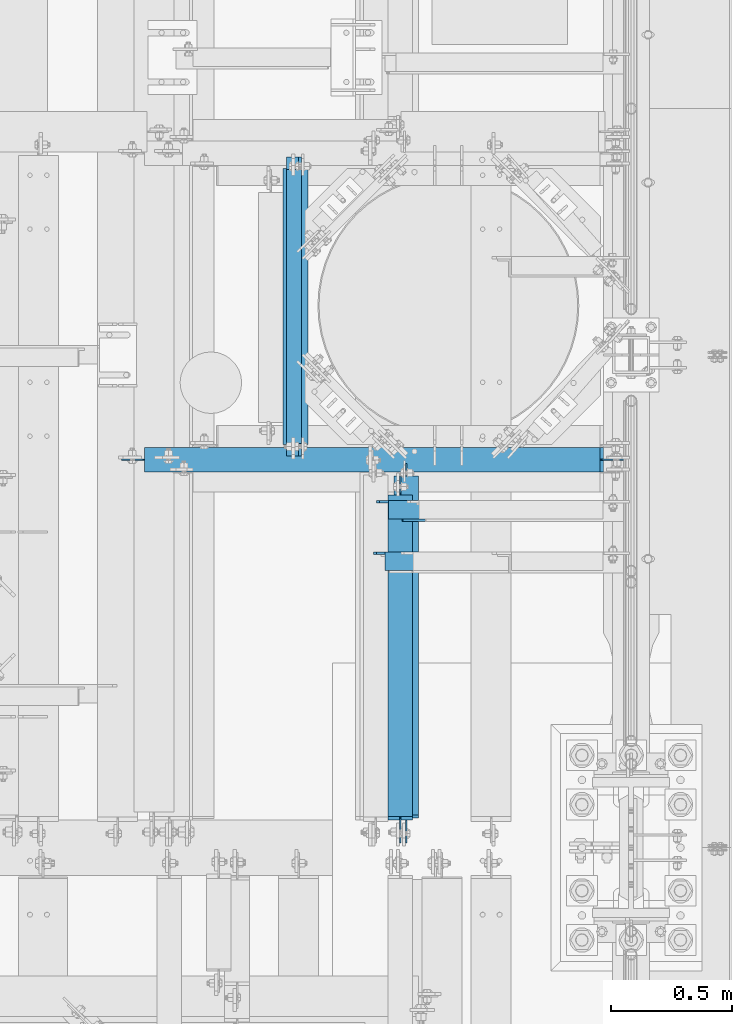
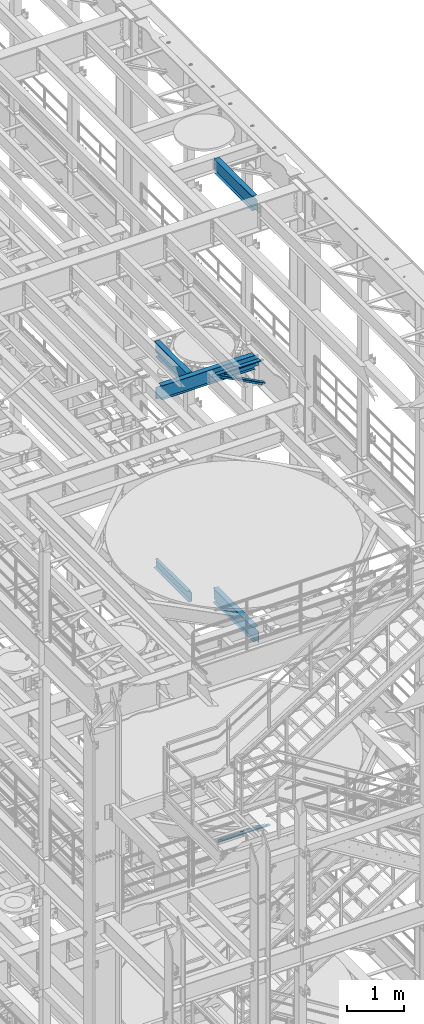
# One storey, part 1028 of 1876: 7 beams, 1 member, 8 elements without a shape of their own.
"""IFC2X3 building model written with IfcOpenShell, lengths in millimetres."""

import ifcopenshell
import ifcopenshell.guid

model = None  # the IFC model being written
_history = None  # IfcOwnerHistory: only IFC2X3 demands one
_inside = {}  # id of a spatial element -> (the spatial element, [elements in it])
_under = {}  # id of a project, library or spatial element -> (it, [spatial elements below it])
_declared = {}  # id of a project -> (the project, [libraries it declares])
_typed = {}  # id of a type object -> (the type object, [elements of that type])
_made_of = {}  # id of a material, layer set ... -> (it, [elements and type objects made of it])


def new_model(schema):
    """Start an empty IFC model of exactly this schema.

    Asked for "IFC4X3", IfcOpenShell would pick the latest addendum, in which some entities
    have other attributes; the version numbers below select the first issue.
    IFC2X3 requires an IfcOwnerHistory on every rooted entity: one is made here for all.
    """
    global model, _history
    if schema == "IFC4X3":
        model = ifcopenshell.file(schema_version=(4, 3, 0, 0))
    else:
        model = ifcopenshell.file(schema=schema)
    _inside.clear()
    _under.clear()
    _declared.clear()
    _typed.clear()
    _made_of.clear()
    _history = None
    if model.schema == "IFC2X3":
        org = make("IfcOrganization", Name="unknown")
        user = make(
            "IfcPersonAndOrganization",
            ThePerson=make("IfcPerson", FamilyName="unknown"),
            TheOrganization=org,
        )
        app = make(
            "IfcApplication",
            ApplicationDeveloper=org,
            Version="unknown",
            ApplicationFullName="unknown",
            ApplicationIdentifier="unknown",
        )
        _history = make(
            "IfcOwnerHistory",
            OwningUser=user,
            OwningApplication=app,
            ChangeAction="ADDED",
            CreationDate=0,
        )
    return model


def make(cls, **values):
    """One entity of the class cls with the attributes given. An attribute that is None is left unset."""
    return model.create_entity(
        cls, **{name: value for name, value in values.items() if value is not None}
    )


def rooted(cls, **values):
    """An entity with a GlobalId (a new one), such as an element, a storey or a relation."""
    return make(cls, GlobalId=ifcopenshell.guid.new(), OwnerHistory=_history, **values)


def si_unit(unit_type, name, prefix=None):
    """IfcSIUnit, for example si_unit("LENGTHUNIT", "METRE", prefix="MILLI")."""
    return make("IfcSIUnit", UnitType=unit_type, Prefix=prefix, Name=name)


def assignment(units):
    """IfcUnitAssignment: the units of a project."""
    return None if units is None else make("IfcUnitAssignment", Units=units)


def point(xyz):
    """IfcCartesianPoint."""
    return None if xyz is None else make("IfcCartesianPoint", Coordinates=xyz)


def direction(xyz):
    """IfcDirection."""
    return None if xyz is None else make("IfcDirection", DirectionRatios=xyz)


def frame(location, z_axis=None, x_axis=None):
    """IfcAxis2Placement3D, a coordinate frame: its origin and axes. An axis left out is left unset."""
    return make(
        "IfcAxis2Placement3D",
        Location=point(location),
        Axis=direction(z_axis),
        RefDirection=direction(x_axis),
    )


def origin_with_axes():
    """The frame at (0, 0, 0) with the z axis (0, 0, 1) and the x axis (1, 0, 0) written out."""
    return frame((0.0, 0.0, 0.0), z_axis=(0.0, 0.0, 1.0), x_axis=(1.0, 0.0, 0.0))


def place(relative_to, where):
    """IfcLocalPlacement: puts the frame where relative to a parent placement (None: the world)."""
    return make(
        "IfcLocalPlacement", PlacementRelTo=relative_to, RelativePlacement=where
    )


def context(
    kind, dimensions, precision=None, world=None, true_north=None, identifier=None
):
    """IfcGeometricRepresentationContext, for example the 3D "Model" context."""
    return make(
        "IfcGeometricRepresentationContext",
        ContextIdentifier=identifier,
        ContextType=kind,
        CoordinateSpaceDimension=dimensions,
        Precision=precision,
        WorldCoordinateSystem=world,
        TrueNorth=true_north,
    )


def subcontext(parent, identifier, kind, view, scale=None):
    """IfcGeometricRepresentationSubContext, for example "Body" below "Model"."""
    return make(
        "IfcGeometricRepresentationSubContext",
        ContextIdentifier=identifier,
        ContextType=kind,
        ParentContext=parent,
        TargetScale=scale,
        TargetView=view,
    )


def project(units=None, contexts=None):
    """IfcProject with its units and contexts."""
    return rooted(
        "IfcProject",
        Name="project",
        RepresentationContexts=contexts,
        UnitsInContext=assignment(units),
    )


def spatial(cls, under=None, at=None, **own):
    """A site, building, storey or space (cls), placed at a placement, below another one or the project."""
    s = rooted(cls, ObjectPlacement=at, **own)
    if under is not None:
        _under.setdefault(under.id(), (under, []))[1].append(s)
    return s


def faces_of(points, faces, orient=None, outer=None):
    """IfcFace entities. A face is a list of loops; a loop is a list of indices into points, from 0.

    orient and outer hold one flag for each loop. By default every Orientation is true, the
    first loop of a face is its IfcFaceOuterBound and the others are IfcFaceBound.
    """
    made = []
    for i, loops in enumerate(faces):
        bounds = []
        for j, loop in enumerate(loops):
            is_outer = j == 0 if outer is None else outer[i][j]
            bounds.append(
                make(
                    "IfcFaceOuterBound" if is_outer else "IfcFaceBound",
                    Bound=make("IfcPolyLoop", Polygon=[points[k] for k in loop]),
                    Orientation=True if orient is None else orient[i][j],
                )
            )
        made.append(make("IfcFace", Bounds=bounds))
    return made


def faceted_brep(points, faces, orient=None, outer=None, voids=None):
    """IfcFacetedBrep: a solid bounded by flat faces; with voids (closed shells), ...WithVoids."""
    shared = [point(p) for p in points]
    hull = make("IfcClosedShell", CfsFaces=faces_of(shared, faces, orient, outer))
    if voids is None:
        return make("IfcFacetedBrep", Outer=hull)
    return make(
        "IfcFacetedBrepWithVoids",
        Outer=hull,
        Voids=[
            make(cls, CfsFaces=faces_of(shared, fs, o, b)) for cls, fs, o, b in voids
        ],
    )


def shape(context_of_items, identifier, shape_type, items):
    """IfcShapeRepresentation: the items that make up one representation, for example the "Body"."""
    return make(
        "IfcShapeRepresentation",
        ContextOfItems=context_of_items,
        RepresentationIdentifier=identifier,
        RepresentationType=shape_type,
        Items=items,
    )


def material(Name=None, Category=None):
    """IfcMaterial."""
    return make("IfcMaterial", Name=Name, Category=Category)


def made_of(thing, what):
    """Note that an element or type object is made of a material, layer set ...; save() writes the relation."""
    if what is not None:
        _made_of.setdefault(what.id(), (what, []))[1].append(thing)
    return thing


def type_object(cls, material=None, **own):
    """A type object (cls), such as IfcWallType, which elements share."""
    return made_of(rooted(cls, **own), material)


def element(
    cls,
    number,
    at=None,
    inside=None,
    cuts=None,
    type_object=None,
    material=None,
    context=None,
    identifier="Body",
    shape_type=None,
    held_by="IfcProductDefinitionShape",
    body=None,
    shapes=None,
    **own,
):
    """One element of the class cls, such as IfcWall. Its Tag is "e" and its number.

    at: its placement. inside: the storey or other place that contains it. cuts: it is an
    opening in that element (IfcRelVoidsElement). A single representation is given by context,
    identifier, shape_type and body (its items); several are given by shapes. held_by: the class
    of the entity that holds the representations. save() writes the other relations.
    """
    e = rooted(cls, Tag="e%d" % number, ObjectPlacement=at, **own)
    if body is not None:
        shapes = [shape(context, identifier, shape_type, body)]
    if shapes is not None:
        e.Representation = make(held_by, Representations=shapes)
    if inside is not None:
        _inside.setdefault(inside.id(), (inside, []))[1].append(e)
    if cuts is not None:
        rooted(
            "IfcRelVoidsElement", RelatingBuildingElement=cuts, RelatedOpeningElement=e
        )
    if type_object is not None:
        _typed.setdefault(type_object.id(), (type_object, []))[1].append(e)
    return made_of(e, material)


def aggregate(whole, parts):
    """IfcRelAggregates: a whole, such as a stair, and the parts it consists of."""
    return rooted("IfcRelAggregates", RelatingObject=whole, RelatedObjects=parts)


def save(model, path):
    """Write the relations noted so far, then the file.

    IfcRelAggregates (storeys below a building ...), IfcRelContainedInSpatialStructure (elements
    in a storey), IfcRelDefinesByType, IfcRelAssociatesMaterial and IfcRelDeclares: one each for
    every whole, place, type object, material and project.
    """
    for whole, parts in _under.values():
        aggregate(whole, parts)
    for where, things in _inside.values():
        rooted(
            "IfcRelContainedInSpatialStructure",
            RelatedElements=things,
            RelatingStructure=where,
        )
    for kind, things in _typed.values():
        rooted("IfcRelDefinesByType", RelatedObjects=things, RelatingType=kind)
    for what, things in _made_of.values():
        rooted("IfcRelAssociatesMaterial", RelatedObjects=things, RelatingMaterial=what)
    for by, libraries in _declared.values():
        rooted("IfcRelDeclares", RelatingContext=by, RelatedDefinitions=libraries)
    model.write(path)


model = new_model("IFC2X3")

# Units and contexts
model_context = context("Model", 3, precision=1e-05, world=origin_with_axes())
body_context = subcontext(model_context, "Body", "Model", "MODEL_VIEW")
ifc_project = project(units=[si_unit("LENGTHUNIT", "METRE", prefix="MILLI"), si_unit("AREAUNIT", "SQUARE_METRE"), si_unit("VOLUMEUNIT", "CUBIC_METRE"), si_unit("MASSUNIT", "GRAM", prefix="KILO"), si_unit("TIMEUNIT", "SECOND"), si_unit("PLANEANGLEUNIT", "RADIAN"), si_unit("SOLIDANGLEUNIT", "STERADIAN"), si_unit("THERMODYNAMICTEMPERATUREUNIT", "DEGREE_CELSIUS"), si_unit("LUMINOUSINTENSITYUNIT", "LUMEN")], contexts=[model_context])

# Site, building, storey
site_placement = place(None, origin_with_axes())
site = spatial("IfcSite", under=ifc_project, at=site_placement, CompositionType="ELEMENT")
building_placement = place(site_placement, origin_with_axes())
building = spatial("IfcBuilding", under=site, at=building_placement, Name="Undefined", CompositionType="ELEMENT")
storey_placement = place(building_placement, origin_with_axes())
storey = spatial("IfcBuildingStorey", under=building, at=storey_placement, Name="Undefined", CompositionType="ELEMENT", Elevation=0.0)

# Assembly, member
assembly_1_placement = place(storey_placement, origin_with_axes())
assembly_1 = element("IfcElementAssembly", 1, at=assembly_1_placement, inside=storey, AssemblyPlace="NOTDEFINED", PredefinedType="RIGID_FRAME")
ifc_material_1 = material(Name="STEEL/A36")
member_type = type_object("IfcMemberType", Name="L3X3X3/8", PredefinedType="NOTDEFINED")
member_placement = place(assembly_1_placement, frame((6548.05484608427, 2908.3, 17987.6375508032), z_axis=(0.0, -1.0, 0.0), x_axis=(0.883528850284789, 0.0, -0.46837674015096)))
member = element("IfcMember", 2, at=member_placement, type_object=member_type, material=ifc_material_1, ObjectType="L3X3X3/8", context=body_context, shape_type="Brep", body=[
    faceted_brep([(128.795891913077, 38.1000000000095, -38.0999999999999), (128.795891913077, 38.1000000000095, 38.0999999999999), (1170.59703232476, 38.0999999999913, 38.0999999999999), (1170.59703232476, 38.0999999999913, -38.0999999999999), (128.795891913076, 28.575000000008, 38.0999999999999), (1170.59703232476, 28.5749999999898, 38.0999999999999), (128.795891913076, 28.575000000008, -28.5749999999998), (1170.59703232476, 28.5749999999898, -28.5749999999998), (128.79589191308, -38.1000000000167, -28.5749999999998), (1170.59703232476, -38.1000000000313, -28.5749999999998), (128.79589191308, -38.1000000000167, -38.0999999999999), (1170.59703232476, -38.1000000000313, -38.0999999999999)], [[[0, 1, 2, 3]], [[1, 4, 5, 2]], [[4, 6, 7, 5]], [[6, 8, 9, 7]], [[8, 10, 11, 9]], [[10, 0, 3, 11]], [[5, 7, 9, 11, 3, 2]], [[10, 8, 6, 4, 1, 0]]]),
])
aggregate(assembly_1, [member])

# Assembly, beam
assembly_2_placement = place(storey_placement, origin_with_axes())
assembly_2 = element("IfcElementAssembly", 3, at=assembly_2_placement, inside=storey, Name="ANGLE", AssemblyPlace="NOTDEFINED", PredefinedType="RIGID_FRAME")
beam_type_1 = type_object("IfcBeamType", Name="L3X3X3/8", PredefinedType="NOTDEFINED")
beam_1_placement = place(assembly_2_placement, frame((6565.90000005887, 2917.825, 17945.1), z_axis=(0.0, -1.0, 0.0), x_axis=(1.0, 0.0, 0.0)))
beam_1 = element("IfcBeam", 4, at=beam_1_placement, type_object=beam_type_1, material=ifc_material_1, Name="ANGLE", ObjectType="L3X3X3/8", context=body_context, shape_type="Brep", body=[
    faceted_brep([(52.3875000813496, 38.0999999999985, 38.0999999999858), (52.3875000813123, 28.5750001907327, 38.0999999999858), (938.213001286278, 28.5750000000007, 38.0999999999999), (938.213001286278, 38.0999999999985, 38.0999999999999), (52.3875051486311, 28.5750000000007, -28.5750000000144), (938.213000419482, 28.5750000000007, -28.5749999999998), (1015.20625603472, 12.6999992370475, -28.5749999999998), (1015.20625591089, 12.6999992370475, -38.0999999999999), (938.213000295654, 12.6999992370475, -38.0999999999999), (938.213000419482, 12.6999992370475, -28.5749999999998), (938.213000295654, 38.0999999999985, -38.0999999999999), (52.3875058725371, 38.0999999999985, -38.1000000000149), (52.3875058725339, 28.5750001907327, -38.1000000000149), (15.8749999382144, 28.5750001907327, -38.0999999999999), (15.8749936676099, 28.5749999999989, -28.5750000000007), (3.17500012894925, 15.8750003814675, -38.0999999999999), (3.17500032897624, 15.8750003814675, -28.5749999999998), (3.17499999075153, -38.0999999999985, -28.5749999999998), (3.17499999075153, -38.0999999999985, -38.0999999999999), (1046.95625011747, -38.0999999999985, -28.5749999999998), (1046.95625603472, -19.0500007629525, -28.5749999999998), (1046.95625591089, -19.0500007629525, -38.0999999999999), (1046.95625011747, -38.0999999999985, -38.0999999999999)], [[[0, 1, 2, 3]], [[1, 4, 5, 2]], [[6, 7, 8, 9]], [[2, 5, 9, 8, 10, 3]], [[11, 0, 3, 10]], [[1, 0, 11, 12, 4]], [[4, 12, 13, 14]], [[14, 13, 15, 16]], [[17, 16, 15, 18]], [[6, 9, 5, 4, 14, 16, 17, 19, 20]], [[7, 6, 20, 21]], [[18, 15, 13, 12, 11, 10, 8, 7, 21, 22]], [[17, 18, 22, 19]], [[21, 20, 19, 22]]]),
])
aggregate(assembly_2, [beam_1])

assembly_3_placement = place(storey_placement, origin_with_axes())
assembly_3 = element("IfcElementAssembly", 5, at=assembly_3_placement, inside=storey, Name="ANGLE", AssemblyPlace="NOTDEFINED", PredefinedType="RIGID_FRAME")
beam_2_placement = place(assembly_3_placement, frame((6553.19999999857, 2705.1, 8115.3), z_axis=(0.0, -1.0, 0.0), x_axis=(1.0, 0.0, 0.0)))
beam_2 = element("IfcBeam", 6, at=beam_2_placement, type_object=beam_type_1, material=ifc_material_1, Name="ANGLE", ObjectType="L3X3X3/8", context=body_context, shape_type="Brep", body=[
    faceted_brep([(950.913000303442, 28.5749999999998, -28.5749999999998), (950.913001170238, 28.5749999999998, 38.0999999999999), (52.3870335430847, 28.5750001907327, 38.0999999999858), (52.3869956588824, 28.5749999999955, -28.5750000000007), (950.913001170238, 38.1000000000004, 38.0999999999999), (52.387033543122, 38.0999999999985, 38.0999999999858), (15.8749936676099, 28.5749999999989, -28.5750000000007), (15.8749999382144, 28.5750001907327, -38.0999999999999), (3.17500012894925, 15.8750003814675, -38.0999999999999), (3.17500032897624, 15.8750003814675, -28.5749999999998), (52.3870393343063, 28.5750001907327, -38.1000000000149), (52.3869953826566, 38.0999999999954, -38.0999999999985), (950.913000179614, 38.1000000000004, -38.0999999999999), (950.913000303442, 12.6999992370611, -28.5749999999998), (950.913000179614, 12.6999992370611, -38.0999999999999), (1027.90624828928, 12.6999992370611, -28.5749999999998), (1027.90624816545, 12.6999992370611, -38.0999999999999), (1059.65624828928, -19.0500007629389, -28.5749999999998), (1059.65624816545, -19.0500007629389, -38.0999999999999), (1059.65625000143, -38.1000000000004, -28.5749999999998), (1059.65625000143, -38.1000000000004, -38.0999999999999), (3.17499999075153, -38.0999999999985, -28.5749999999998), (3.17499999075153, -38.0999999999985, -38.0999999999999), (3.17500012894925, 3.17500152587672, -38.0999999999999), (3.17500032897624, 3.17500152587672, -28.5749999999998)], [[[0, 1, 2, 3]], [[1, 4, 5, 2]], [[6, 7, 8, 9]], [[3, 10, 7, 6]], [[2, 5, 11, 10, 3]], [[4, 12, 11, 5]], [[1, 0, 13, 14, 12, 4]], [[15, 16, 14, 13]], [[16, 15, 17, 18]], [[18, 17, 19, 20]], [[20, 19, 21, 22]], [[8, 7, 10, 11, 12, 14, 16, 18, 20, 22, 23]], [[9, 8, 23, 24]], [[19, 17, 15, 13, 0, 3, 6, 9, 24, 21]], [[23, 22, 21, 24]]]),
])
aggregate(assembly_3, [beam_2])

assembly_4_placement = place(storey_placement, origin_with_axes())
assembly_4 = element("IfcElementAssembly", 7, at=assembly_4_placement, inside=storey, Name="BEAM", AssemblyPlace="NOTDEFINED", PredefinedType="RIGID_FRAME")
ifc_material_2 = material(Name="STEEL/A992")
beam_type_2 = type_object("IfcBeamType", Name="W12X16", PredefinedType="NOTDEFINED")
beam_3_placement = place(assembly_4_placement, frame((6235.7, 3124.19999994922, 17830.8), z_axis=(0.0, 0.0, 1.0), x_axis=(0.0, 1.0, 0.0)))
beam_3 = element("IfcBeam", 8, at=beam_3_placement, type_object=beam_type_2, material=ifc_material_2, Name="BEAM", ObjectType="W12X16", context=body_context, shape_type="Brep", body=[
    faceted_brep([(15.8749999999982, -3.17500000000018, -127.0), (15.8749999999982, 3.17500000000018, -127.0), (92.0750001154556, 3.17500000000018, -126.999999999996), (92.0750001154556, -3.17500000000018, -126.999999999996), (96.9350796335011, 3.17500000000018, -127.966729922584), (96.9350796335011, -3.17500000000018, -127.966729922584), (101.055256101655, 3.17500000000018, -130.719743823061), (101.055256101655, -3.17500000000018, -130.719743823061), (103.808270002133, 3.17500000000018, -134.839920291215), (103.808270002133, -3.17500000000018, -134.839920291215), (104.774999924721, -3.17500000000018, -139.699999809261), (104.774999924721, 3.17500000000018, -139.699999809261), (104.774999924721, 3.17500000000018, -146.049999999999), (104.774999924721, 50.8000000000002, -146.049999999999), (104.774999924721, 50.8000000000002, -152.400000000001), (104.774999924721, -50.8000000000002, -152.400000000001), (104.774999924721, -50.8000000000002, -146.049999999999), (104.774999924721, -3.17500000000018, -146.049999999999), (1200.15000005078, 50.8000000000002, 146.049999999999), (1200.15000005078, 3.17500000000018, 146.049999999999), (63.5000000000009, 3.17499999999927, 146.049999999999), (63.4999999247211, 50.8000000000002, 146.049999999999), (50.800000115456, -3.17500000000018, 127.000000000004), (50.800000115456, 3.17500000000018, 127.000000000004), (15.875, 3.17500000000018, 127.000000000001), (15.875, -3.17500000000018, 127.000000000001), (55.6600796335015, -3.17500000000018, 127.966729922591), (55.6600796335015, 3.17500000000018, 127.966729922591), (59.7802561016551, -3.17500000000018, 130.719743823069), (59.7802561016551, 3.17500000000018, 130.719743823069), (62.5332700021336, -3.17500000000018, 134.839920291222), (62.5332700021336, 3.17500000000018, 134.839920291222), (63.4999999247211, -3.17500000000018, 139.699999809269), (63.4999999247211, 3.17500000000018, 139.699999809269), (1200.15000005078, -50.8000000000002, 152.400000000001), (1200.15000005078, 50.8000000000002, 152.400000000001), (63.4999999247211, 50.8000000000002, 152.400000000001), (63.4999999247211, -50.8000000000002, 152.400000000001), (1200.15000005078, -50.8000000000002, 146.049999999999), (63.4999999247211, -50.8000000000002, 146.049999999999), (1200.15000005078, -3.17500000000018, 146.049999999999), (63.5000000000009, -3.17499999999927, 146.049999999999), (1200.15000005078, -3.17500000000018, 139.699999809269), (1200.15000005078, 3.17500000000018, 139.699999809269), (1201.11672997337, -3.17500000000018, 134.839920291222), (1201.11672997337, 3.17500000000018, 134.839920291222), (1203.86974387385, -3.17500000000018, 130.719743823069), (1203.86974387385, 3.17500000000018, 130.719743823069), (1207.989920342, -3.17500000000018, 127.966729922591), (1207.989920342, 3.17500000000018, 127.966729922591), (1212.84999986005, -3.17500000000018, 127.000000000004), (1212.84999986005, 3.17500000000018, 127.000000000004), (1247.77500005078, -3.17500000000018, 127.000000000004), (1247.77500005078, 3.17500000000018, 127.000000000004), (1247.77500005078, -3.17500000000018, -126.999999999996), (1247.77500005078, 3.17500000000018, -126.999999999996), (1171.57499986005, -3.17500000000018, -126.999999999996), (1171.57499986005, 3.17500000000018, -126.999999999996), (1166.714920342, -3.17500000000018, -127.966729922584), (1166.714920342, 3.17500000000018, -127.966729922584), (1162.59474387385, -3.17500000000018, -130.719743823061), (1162.59474387385, 3.17500000000018, -130.719743823061), (1159.84172997337, -3.17500000000018, -134.839920291215), (1159.84172997337, 3.17500000000018, -134.839920291215), (1158.87500005078, -3.17500000000018, -139.699999809261), (1158.87500005078, 3.17500000000018, -139.699999809261), (1158.87500005078, -3.17500000000018, -146.049999999999), (1158.87500005078, -50.8000000000002, -146.049999999999), (1158.87500005078, -50.8000000000002, -152.400000000001), (1158.87500005078, 50.8000000000002, -152.400000000001), (1158.87500005078, 50.8000000000002, -146.049999999999), (1158.87500005078, 3.17500000000018, -146.049999999999)], [[[0, 1, 2, 3]], [[3, 2, 4, 5]], [[5, 4, 6, 7]], [[7, 6, 8, 9]], [[10, 11, 12, 13, 14, 15, 16, 17]], [[9, 8, 11, 10]], [[18, 19, 20, 21]], [[22, 23, 24, 25]], [[26, 27, 23, 22]], [[28, 29, 27, 26]], [[30, 31, 29, 28]], [[32, 33, 31, 30]], [[34, 35, 36, 37]], [[38, 34, 37, 39]], [[40, 38, 39, 41]], [[37, 36, 21, 20, 33, 32, 41, 39]], [[35, 18, 21, 36]], [[34, 38, 40, 42, 43, 19, 18, 35]], [[44, 45, 43, 42]], [[46, 47, 45, 44]], [[48, 49, 47, 46]], [[50, 51, 49, 48]], [[52, 53, 51, 50]], [[53, 52, 54, 55]], [[54, 56, 57, 55]], [[58, 59, 57, 56]], [[60, 61, 59, 58]], [[62, 63, 61, 60]], [[64, 65, 63, 62]], [[66, 67, 68, 69, 70, 71, 65, 64]], [[67, 66, 17, 16]], [[68, 67, 16, 15]], [[69, 68, 15, 14]], [[70, 69, 14, 13]], [[71, 70, 13, 12]], [[6, 4, 2, 1, 24, 23, 27, 29, 31, 33, 20, 19, 43, 45, 47, 49, 51, 53, 55, 57, 59, 61, 63, 65, 71, 12, 11, 8]], [[25, 24, 1, 0]], [[66, 64, 62, 60, 58, 56, 54, 52, 50, 48, 46, 44, 42, 40, 41, 32, 30, 28, 26, 22, 25, 0, 3, 5, 7, 9, 10, 17]]]),
])
aggregate(assembly_4, [beam_3])

assembly_5_placement = place(storey_placement, origin_with_axes())
assembly_5 = element("IfcElementAssembly", 9, at=assembly_5_placement, inside=storey, Name="BEAM", AssemblyPlace="NOTDEFINED", PredefinedType="RIGID_FRAME")
beam_4_placement = place(assembly_5_placement, frame((5638.8, 3124.2, 17830.8), z_axis=(0.0, 0.0, 1.0), x_axis=(1.0, 0.0, 0.0)))
beam_4 = element("IfcBeam", 10, at=beam_4_placement, type_object=beam_type_2, material=ifc_material_2, Name="BEAM", ObjectType="W12X16", context=body_context, shape_type="Brep", body=[
    faceted_brep([(1866.10625, -3.17500000000018, -146.049999999999), (1866.10625, -50.8000000000002, -146.049999999999), (1866.10625, -50.8000000000002, -152.400000000001), (1866.10625, 50.8000000000002, -152.400000000001), (1866.10625, 50.8000000000002, -146.049999999999), (1866.10625, 3.17500000000018, -146.049999999999), (1866.10625, 3.17500000000018, -139.699999809261), (1866.10625, -3.17500000000018, -139.699999809261), (1867.07297992259, 3.17500000000018, -134.839920291215), (1867.07297992259, -3.17500000000018, -134.839920291215), (1869.82599382306, 3.17500000000018, -130.719743823061), (1869.82599382306, -3.17500000000018, -130.719743823061), (1873.94617029122, 3.17500000000018, -127.966729922584), (1873.94617029122, -3.17500000000018, -127.966729922584), (1878.80624980926, 3.17500000000018, -126.999999999996), (1878.80624980926, -3.17500000000018, -126.999999999996), (1961.35625, -3.17500000000018, -126.999999999996), (1961.35625, 3.17500000000018, -126.999999999996), (-25.3999999999996, 3.17500000000018, 146.049999999999), (-25.3999999999996, 50.8000000000002, 146.049999999999), (1853.40625, 50.8000000000002, 146.049999999999), (1853.40625, 3.17500000000018, 146.049999999999), (-25.3999999999996, -3.17500000000018, -139.699999809269), (-25.3999999999996, 3.17500000000018, -139.699999809269), (-25.3999999999996, 3.17500000000018, -146.049999999999), (-25.3999999999996, 50.8000000000002, -146.049999999999), (-25.3999999999996, 50.8000000000002, -152.400000000001), (-25.3999999999996, -50.8000000000002, -152.400000000001), (-25.3999999999996, -50.8000000000002, -146.049999999999), (-25.3999999999996, -3.17500000000018, -146.049999999999), (-26.3667299225872, -3.17500000000018, -134.839920291222), (-26.3667299225872, 3.17500000000018, -134.839920291222), (-29.1197438230656, -3.17500000000018, -130.719743823069), (-29.1197438230656, 3.17500000000018, -130.719743823069), (-33.2399202912193, -3.17500000000018, -127.966729922591), (-33.2399202912193, 3.17500000000018, -127.966729922591), (-38.0999998092648, -3.17500000000018, -127.000000000004), (-38.0999998092648, 3.17500000000018, -127.000000000004), (-120.65, -3.17500000000018, -127.000000000004), (-120.65, 3.17500000000018, -127.000000000004), (-120.65, -3.17500000000018, 126.999999999996), (-120.65, 3.17500000000018, 126.999999999996), (-38.0999998092648, -3.17500000000018, 126.999999999996), (-38.0999998092648, 3.17500000000018, 126.999999999996), (-33.2399202912193, -3.17500000000018, 127.966729922584), (-33.2399202912193, 3.17500000000018, 127.966729922584), (-29.1197438230656, -3.17500000000018, 130.719743823061), (-29.1197438230656, 3.17500000000018, 130.719743823061), (-26.3667299225872, -3.17500000000018, 134.839920291215), (-26.3667299225872, 3.17500000000018, 134.839920291215), (-25.3999999999996, -3.17500000000018, 139.699999809261), (-25.3999999999996, 3.17500000000018, 139.699999809261), (-25.3999999999996, -50.8000000000002, 152.400000000001), (-25.3999999999996, 50.8000000000002, 152.400000000001), (-25.3999999999996, -3.17500000000018, 146.049999999999), (-25.3999999999996, -50.8000000000002, 146.049999999999), (1853.40625, -3.17500000000018, 146.049999999999), (1853.40625, -50.8000000000002, 146.049999999999), (1853.40625, -50.8000000000002, 152.400000000001), (1853.40625, 50.8000000000002, 152.400000000001), (1853.40625, -3.17500000000018, 126.999999809268), (1853.40625, 3.17500000000018, 126.999999809268), (1854.37297992259, -3.17500000000018, 122.139920291222), (1854.37297992259, 3.17500000000018, 122.139920291222), (1857.12599382306, -3.17500000000018, 118.019743823068), (1857.12599382306, 3.17500000000018, 118.019743823068), (1861.24617029122, -3.17500000000018, 115.26672992259), (1861.24617029122, 3.17500000000018, 115.26672992259), (1866.10624980926, -3.17500000000018, 114.300000000003), (1866.10624980926, 3.17500000000018, 114.300000000003), (1961.35625, -3.17500000000018, 114.300000000003), (1961.35625, 3.17500000000018, 114.300000000003)], [[[0, 1, 2, 3, 4, 5, 6, 7]], [[7, 6, 8, 9]], [[9, 8, 10, 11]], [[11, 10, 12, 13]], [[13, 12, 14, 15]], [[16, 15, 14, 17]], [[18, 19, 20, 21]], [[22, 23, 24, 25, 26, 27, 28, 29]], [[30, 31, 23, 22]], [[32, 33, 31, 30]], [[34, 35, 33, 32]], [[36, 37, 35, 34]], [[38, 39, 37, 36]], [[40, 41, 39, 38]], [[42, 43, 41, 40]], [[44, 45, 43, 42]], [[46, 47, 45, 44]], [[48, 49, 47, 46]], [[50, 51, 49, 48]], [[52, 53, 19, 18, 51, 50, 54, 55]], [[55, 54, 56, 57]], [[52, 55, 57, 58]], [[53, 52, 58, 59]], [[19, 53, 59, 20]], [[58, 57, 56, 60, 61, 21, 20, 59]], [[62, 63, 61, 60]], [[64, 65, 63, 62]], [[66, 67, 65, 64]], [[68, 69, 67, 66]], [[70, 71, 69, 68]], [[71, 70, 16, 17]], [[12, 10, 8, 6, 5, 24, 23, 31, 33, 35, 37, 39, 41, 43, 45, 47, 49, 51, 18, 21, 61, 63, 65, 67, 69, 71, 17, 14]], [[25, 24, 5, 4]], [[26, 25, 4, 3]], [[27, 26, 3, 2]], [[28, 27, 2, 1]], [[29, 28, 1, 0]], [[70, 68, 66, 64, 62, 60, 56, 54, 50, 48, 46, 44, 42, 40, 38, 36, 34, 32, 30, 22, 29, 0, 7, 9, 11, 13, 15, 16]]]),
])
aggregate(assembly_5, [beam_4])

assembly_6_placement = place(storey_placement, origin_with_axes())
assembly_6 = element("IfcElementAssembly", 11, at=assembly_6_placement, inside=storey, Name="BEAM", AssemblyPlace="NOTDEFINED", PredefinedType="RIGID_FRAME")
beam_5_placement = place(assembly_6_placement, frame((6692.9, 1524.0, 13157.2), z_axis=(0.0, 0.0, 1.0), x_axis=(0.0, 1.0, 0.0)))
beam_5 = element("IfcBeam", 12, at=beam_5_placement, type_object=beam_type_2, material=ifc_material_2, Name="BEAM", ObjectType="W12X16", context=body_context, shape_type="Brep", body=[
    faceted_brep([(19.84375, -3.17499999999995, -126.999999999996), (19.84375, 3.17499999999995, -126.999999999996), (108.743750190735, 3.17500000000018, -127.0), (108.743750190735, -3.17500000000018, -127.0), (113.603829708781, 3.17500000000018, -127.966729922588), (113.603829708781, -3.17500000000018, -127.966729922588), (117.724006176934, 3.17500000000018, -130.719743823065), (117.724006176934, -3.17500000000018, -130.719743823065), (120.477020077413, 3.17500000000018, -134.839920291219), (120.477020077413, -3.17500000000018, -134.839920291219), (121.44375, -3.17500000000018, -139.699999809265), (121.44375, 3.17500000000018, -139.699999809265), (121.44375, 3.17500000000018, -146.049999999999), (121.44375, 50.8000000000002, -146.049999999999), (121.44375, 50.8000000000002, -152.4), (121.44375, -50.8000000000002, -152.4), (121.44375, -50.8000000000002, -146.049999999999), (121.44375, -3.17500000000018, -146.049999999999), (1533.525, 50.8000000000002, 146.049999999999), (1533.525, 3.17500000000018, 146.049999999999), (134.14375, 3.17500000000018, 146.049999999999), (134.14375, 50.8000000000002, 146.049999999999), (121.443750190735, -3.17500000000018, 114.299999999999), (121.443750190735, 3.17500000000018, 114.299999999999), (19.84375, 3.17500000000018, 114.299999999999), (19.84375, -3.17500000000018, 114.299999999999), (126.303829708781, -3.17500000000018, 115.266729922587), (126.303829708781, 3.17500000000018, 115.266729922587), (130.424006176934, -3.17500000000018, 118.019743823064), (130.424006176934, 3.17500000000018, 118.019743823064), (133.177020077413, -3.17500000000018, 122.139920291218), (133.177020077413, 3.17500000000018, 122.139920291218), (134.14375, -3.17500000000018, 126.999999809264), (134.14375, 3.17500000000018, 126.999999809264), (1533.525, -50.8000000000002, 152.4), (1533.525, 50.8000000000002, 152.4), (134.14375, 50.8000000000002, 152.4), (134.14375, -50.8000000000002, 152.4), (1533.525, -50.8000000000002, 146.049999999999), (134.14375, -50.8000000000002, 146.049999999999), (1533.525, -3.17500000000018, 146.049999999999), (134.14375, -3.17500000000018, 146.049999999999), (1533.525, -3.17500000000018, 139.699999809265), (1533.525, 3.17500000000018, 139.699999809265), (1534.49172992259, -3.17500000000018, 134.839920291219), (1534.49172992259, 3.17500000000018, 134.839920291219), (1537.24474382307, -3.17500000000018, 130.719743823065), (1537.24474382307, 3.17500000000018, 130.719743823065), (1541.36492029122, -3.17500000000018, 127.966729922588), (1541.36492029122, 3.17500000000018, 127.966729922588), (1546.22499980927, -3.17500000000018, 127.0), (1546.22499980927, 3.17500000000018, 127.0), (1584.325, -3.17500000000018, 127.000000000004), (1584.325, 3.17500000000018, 127.000000000004), (1584.325, -3.17500000000018, -126.999999999996), (1584.325, 3.17500000000018, -126.999999999996), (1546.22499980927, -3.17500000000018, -127.0), (1546.22499980927, 3.17500000000018, -127.0), (1541.36492029122, -3.17500000000018, -127.966729922588), (1541.36492029122, 3.17500000000018, -127.966729922588), (1537.24474382307, -3.17500000000018, -130.719743823065), (1537.24474382307, 3.17500000000018, -130.719743823065), (1534.49172992259, -3.17500000000018, -134.839920291219), (1534.49172992259, 3.17500000000018, -134.839920291219), (1533.525, -3.17500000000018, -139.699999809265), (1533.525, 3.17500000000018, -139.699999809265), (1533.525, -3.17500000000018, -146.049999999999), (1533.525, -50.8000000000002, -146.049999999999), (1533.525, -50.8000000000002, -152.4), (1533.525, 50.8000000000002, -152.4), (1533.525, 50.8000000000002, -146.049999999999), (1533.525, 3.17500000000018, -146.049999999999)], [[[0, 1, 2, 3]], [[3, 2, 4, 5]], [[5, 4, 6, 7]], [[7, 6, 8, 9]], [[10, 11, 12, 13, 14, 15, 16, 17]], [[9, 8, 11, 10]], [[18, 19, 20, 21]], [[22, 23, 24, 25]], [[26, 27, 23, 22]], [[28, 29, 27, 26]], [[30, 31, 29, 28]], [[32, 33, 31, 30]], [[34, 35, 36, 37]], [[38, 34, 37, 39]], [[40, 38, 39, 41]], [[37, 36, 21, 20, 33, 32, 41, 39]], [[35, 18, 21, 36]], [[34, 38, 40, 42, 43, 19, 18, 35]], [[44, 45, 43, 42]], [[46, 47, 45, 44]], [[48, 49, 47, 46]], [[50, 51, 49, 48]], [[52, 53, 51, 50]], [[53, 52, 54, 55]], [[54, 56, 57, 55]], [[58, 59, 57, 56]], [[60, 61, 59, 58]], [[62, 63, 61, 60]], [[64, 65, 63, 62]], [[66, 67, 68, 69, 70, 71, 65, 64]], [[67, 66, 17, 16]], [[68, 67, 16, 15]], [[69, 68, 15, 14]], [[70, 69, 14, 13]], [[71, 70, 13, 12]], [[6, 4, 2, 1, 24, 23, 27, 29, 31, 33, 20, 19, 43, 45, 47, 49, 51, 53, 55, 57, 59, 61, 63, 65, 71, 12, 11, 8]], [[25, 24, 1, 0]], [[66, 64, 62, 60, 58, 56, 54, 52, 50, 48, 46, 44, 42, 40, 41, 32, 30, 28, 26, 22, 25, 0, 3, 5, 7, 9, 10, 17]]]),
])
aggregate(assembly_6, [beam_5])

assembly_7_placement = place(storey_placement, origin_with_axes())
assembly_7 = element("IfcElementAssembly", 13, at=assembly_7_placement, inside=storey, Name="BEAM", AssemblyPlace="NOTDEFINED", PredefinedType="RIGID_FRAME")
beam_6_placement = place(assembly_7_placement, frame((6667.5, 1524.0, 22402.8), z_axis=(0.0, 0.0, 1.0), x_axis=(0.0, 1.0, 0.0)))
beam_6 = element("IfcBeam", 14, at=beam_6_placement, type_object=beam_type_2, material=ifc_material_2, Name="BEAM", ObjectType="W12X16", context=body_context, shape_type="Brep", body=[
    faceted_brep([(1438.27420043945, -3.17500000000018, -146.049999999999), (1438.27420043945, -50.8000000000002, -146.049999999999), (1438.27420043945, -50.8000000000002, -152.400000000001), (1438.27420043945, 50.8000000000002, -152.400000000001), (1438.27420043945, 50.8000000000002, -146.049999999999), (1438.27420043945, 3.17500000000018, -146.049999999999), (1438.27420043945, 3.17500000000018, -139.699999809265), (1438.27420043945, -3.17500000000018, -139.699999809265), (1439.24093036204, 3.17500000000018, -134.839920291219), (1439.24093036204, -3.17500000000018, -134.839920291219), (1441.99394426252, 3.17500000000018, -130.719743823065), (1441.99394426252, -3.17500000000018, -130.719743823065), (1446.11412073067, 3.17500000000018, -127.966729922588), (1446.11412073067, -3.17500000000018, -127.966729922588), (1450.97420024872, 3.17500000000018, -127.0), (1450.97420024872, -3.17500000000018, -127.0), (1533.52420043945, -3.17500000000018, -127.0), (1533.52420043945, 3.17500000000018, -127.0), (127.79375, 3.17500000000018, 146.05), (127.79375, 50.8000000000002, 146.05), (1454.14920043945, 50.8000000000002, 146.049999999999), (1454.14920043945, 3.17500000000018, 146.049999999999), (115.09375, -3.17500000000018, -139.699999809266), (115.09375, 3.17500000000018, -139.699999809266), (115.09375, 3.17500000000018, -146.05), (115.09375, 50.8000000000002, -146.05), (115.09375, 50.8000000000002, -152.4), (115.09375, -50.8000000000002, -152.4), (115.09375, -50.8000000000002, -146.05), (115.09375, -3.17500000000018, -146.05), (114.127020077412, -3.17500000000018, -134.839920291221), (114.127020077412, 3.17500000000018, -134.839920291221), (111.374006176934, -3.17500000000018, -130.719743823067), (111.374006176934, 3.17500000000018, -130.719743823067), (107.25382970878, -3.17500000000018, -127.966729922588), (107.25382970878, 3.17500000000018, -127.966729922588), (102.393750190735, -3.17500000000018, -127.000000000001), (102.393750190735, 3.17500000000018, -127.000000000001), (19.84375, -3.17499999999995, -126.999999999996), (19.84375, 3.17499999999995, -126.999999999996), (19.84375, -3.17500000000018, 114.299999999999), (19.84375, 3.17500000000018, 114.299999999999), (115.093750190735, -3.17500000000018, 114.299999999999), (115.093750190735, 3.17500000000018, 114.299999999999), (119.95382970878, -3.17500000000018, 115.266729922587), (119.95382970878, 3.17500000000018, 115.266729922587), (124.074006176934, -3.17500000000018, 118.019743823065), (124.074006176934, 3.17500000000018, 118.019743823065), (126.827020077412, -3.17500000000018, 122.139920291219), (126.827020077412, 3.17500000000018, 122.139920291219), (127.79375, -3.17500000000018, 126.999999809264), (127.79375, 3.17500000000018, 126.999999809264), (127.79375, -50.8000000000002, 152.4), (127.79375, 50.8000000000002, 152.4), (127.79375, -3.17500000000018, 146.05), (127.79375, -50.8000000000002, 146.05), (1454.14920043945, -3.17500000000018, 146.049999999999), (1454.14920043945, -50.8000000000002, 146.049999999999), (1454.14920043945, -50.8000000000002, 152.400000000001), (1454.14920043945, 50.8000000000002, 152.400000000001), (1454.14920043945, -3.17500000000018, 126.999999809264), (1454.14920043945, 3.17500000000018, 126.999999809264), (1455.11593036204, -3.17500000000018, 122.139920291218), (1455.11593036204, 3.17500000000018, 122.139920291218), (1457.86894426252, -3.17500000000018, 118.019743823064), (1457.86894426252, 3.17500000000018, 118.019743823064), (1461.98912073067, -3.17500000000018, 115.266729922587), (1461.98912073067, 3.17500000000018, 115.266729922587), (1466.84920024872, -3.17500000000018, 114.299999999999), (1466.84920024872, 3.17500000000018, 114.299999999999), (1533.52420043945, -3.17500000000018, 114.299999999999), (1533.52420043945, 3.17500000000018, 114.299999999999)], [[[0, 1, 2, 3, 4, 5, 6, 7]], [[7, 6, 8, 9]], [[9, 8, 10, 11]], [[11, 10, 12, 13]], [[13, 12, 14, 15]], [[16, 15, 14, 17]], [[18, 19, 20, 21]], [[22, 23, 24, 25, 26, 27, 28, 29]], [[30, 31, 23, 22]], [[32, 33, 31, 30]], [[34, 35, 33, 32]], [[36, 37, 35, 34]], [[38, 39, 37, 36]], [[40, 41, 39, 38]], [[42, 43, 41, 40]], [[44, 45, 43, 42]], [[46, 47, 45, 44]], [[48, 49, 47, 46]], [[50, 51, 49, 48]], [[52, 53, 19, 18, 51, 50, 54, 55]], [[55, 54, 56, 57]], [[52, 55, 57, 58]], [[53, 52, 58, 59]], [[19, 53, 59, 20]], [[58, 57, 56, 60, 61, 21, 20, 59]], [[62, 63, 61, 60]], [[64, 65, 63, 62]], [[66, 67, 65, 64]], [[68, 69, 67, 66]], [[70, 71, 69, 68]], [[71, 70, 16, 17]], [[12, 10, 8, 6, 5, 24, 23, 31, 33, 35, 37, 39, 41, 43, 45, 47, 49, 51, 18, 21, 61, 63, 65, 67, 69, 71, 17, 14]], [[25, 24, 5, 4]], [[26, 25, 4, 3]], [[27, 26, 3, 2]], [[28, 27, 2, 1]], [[29, 28, 1, 0]], [[70, 68, 66, 64, 62, 60, 56, 54, 50, 48, 46, 44, 42, 40, 38, 36, 34, 32, 30, 22, 29, 0, 7, 9, 11, 13, 15, 16]]]),
])
aggregate(assembly_7, [beam_6])

assembly_8_placement = place(storey_placement, origin_with_axes())
assembly_8 = element("IfcElementAssembly", 15, at=assembly_8_placement, inside=storey, Name="BEAM", AssemblyPlace="NOTDEFINED", PredefinedType="RIGID_FRAME")
beam_type_3 = type_object("IfcBeamType", Name="C8X18.75", PredefinedType="NOTDEFINED")
beam_7_placement = place(assembly_8_placement, frame((6229.35, 3124.20000000002, 13208.0), z_axis=(0.0, 0.0, -1.0), x_axis=(0.0, 1.0, 0.0)))
beam_7 = element("IfcBeam", 16, at=beam_7_placement, type_object=beam_type_3, material=ifc_material_1, Name="BEAM", ObjectType="C8X18.75", context=body_context, shape_type="Brep", body=[
    faceted_brep([(1196.97499999998, -31.75, -97.3645500000002), (1196.97499999998, -31.75, -101.6), (1196.97499999998, 31.75, -101.6), (1196.97499999998, 31.75, -95.2499998092662), (1196.97499999998, -19.0576219043587, -95.2499998092662), (1197.94172992257, 31.75, -90.3899202912198), (1197.94172992257, 10.1145240623009, -90.3899202912198), (1198.9364142465, 19.0500000000002, -88.9012700000003), (1200.69474382305, 31.75, -86.2697438230662), (1200.69474382305, 19.0500000000002, -86.2697438230662), (1204.8149202912, 31.75, -83.5167299225886), (1204.8149202912, 19.0500000000002, -83.5167299225886), (1209.67499980925, 31.75, -82.5500000000011), (1209.67499980925, 19.0500000000002, -82.5500000000011), (1247.77499999998, 19.0500000000002, -82.5500000000011), (1247.77499999998, 31.75, -82.5500000000011), (15.8749999999991, -31.75, 101.599999999999), (15.8749999999991, -31.75, 97.3645499999984), (1247.77499999998, -31.75, 97.3645500000002), (1247.77499999998, -31.75, 101.6), (15.8749999999991, 31.75, 101.599999999999), (1247.77499999998, 31.75, 101.6), (66.674999999982, -19.0576219043596, -95.2499998092662), (66.674999999982, 31.75, -95.2499998092662), (66.674999999982, 31.75, -101.6), (66.674999999982, -31.75, -101.6), (66.674999999982, -31.75, -97.3645500000002), (65.708270077394, 10.1145240623009, -90.3899202912198), (65.708270077394, 31.75, -90.3899202912198), (64.7135857534681, 19.0500000000002, -88.9012700000003), (62.955256176916, 19.0500000000002, -86.2697438230662), (62.955256176916, 31.75, -86.2697438230662), (58.8350797087624, 19.0500000000002, -83.5167299225886), (58.8350797087624, 31.75, -83.5167299225886), (53.9750001907169, 19.0500000000002, -82.5500000000011), (53.9750001907169, 31.75, -82.5500000000011), (15.8749999999991, 19.0500000000002, -82.5499999999993), (15.8749999999991, 31.75, -82.5499999999993), (15.8749999999991, 19.0500000000002, 88.9012699999985), (1247.77499999998, 19.0500000000002, 88.9012700000003)], [[[0, 1, 2, 3, 4]], [[4, 3, 5, 6]], [[7, 6, 5, 8, 9]], [[9, 8, 10, 11]], [[11, 10, 12, 13]], [[14, 13, 12, 15]], [[16, 17, 18, 19]], [[20, 16, 19, 21]], [[22, 23, 24, 25, 26]], [[27, 28, 23, 22]], [[29, 30, 31, 28, 27]], [[32, 33, 31, 30]], [[34, 35, 33, 32]], [[36, 37, 35, 34]], [[38, 17, 16, 20, 37, 36]], [[17, 38, 39, 18]], [[21, 19, 18, 39, 14, 15]], [[10, 8, 5, 3, 2, 24, 23, 28, 31, 33, 35, 37, 20, 21, 15, 12]], [[25, 24, 2, 1]], [[26, 25, 1, 0]], [[29, 27, 22, 26, 0, 4, 6, 7]], [[39, 38, 36, 34, 32, 30, 29, 7, 9, 11, 13, 14]]]),
])
aggregate(assembly_8, [beam_7])

save(model, "model.ifc")
